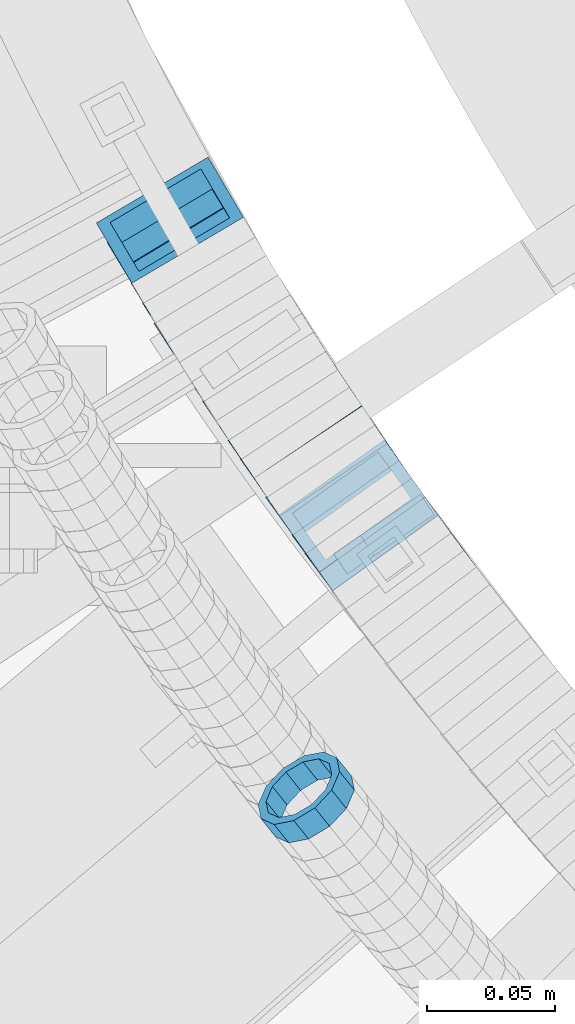
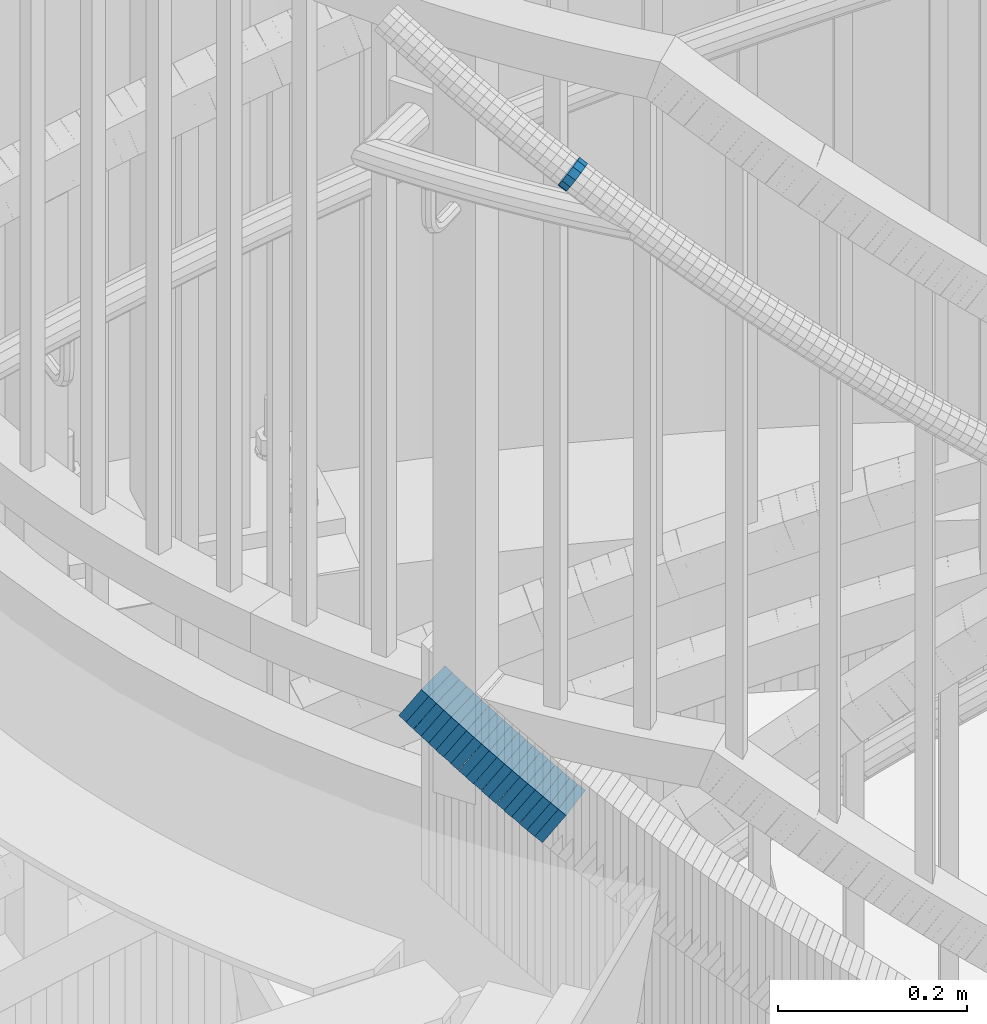
# One storey, part 725 of 975: 20 members.
"""IFC2X3 building model written with IfcOpenShell, lengths in millimetres."""

from ifc_helpers import new_model, si_unit, frame, origin_with_axes, place, context, subcontext, project, spatial, faceted_brep, material, type_object, element, save


model = new_model("IFC2X3")

# Units and contexts
model_context = context("Model", 3, precision=1e-05, world=origin_with_axes())
body_context = subcontext(model_context, "Body", "Model", "MODEL_VIEW")
ifc_project = project(units=[si_unit("LENGTHUNIT", "METRE", prefix="MILLI"), si_unit("AREAUNIT", "SQUARE_METRE"), si_unit("VOLUMEUNIT", "CUBIC_METRE"), si_unit("MASSUNIT", "GRAM", prefix="KILO"), si_unit("TIMEUNIT", "SECOND"), si_unit("PLANEANGLEUNIT", "RADIAN"), si_unit("SOLIDANGLEUNIT", "STERADIAN"), si_unit("THERMODYNAMICTEMPERATUREUNIT", "DEGREE_CELSIUS"), si_unit("LUMINOUSINTENSITYUNIT", "LUMEN")], contexts=[model_context])

# Site, building, storey
site_placement = place(None, origin_with_axes())
site = spatial("IfcSite", under=ifc_project, at=site_placement, CompositionType="ELEMENT")
building_placement = place(site_placement, origin_with_axes())
building = spatial("IfcBuilding", under=site, at=building_placement, Name="Undefined", CompositionType="ELEMENT")
storey_placement = place(building_placement, origin_with_axes())
storey = spatial("IfcBuildingStorey", under=building, at=storey_placement, Name="Undefined", CompositionType="ELEMENT", Elevation=0.0)

# Members
ifc_material = material()
member_type_1 = type_object("IfcMemberType", PredefinedType="NOTDEFINED")
member_1_placement = place(storey_placement, frame((33576.5249931983, 2482.7928515664, 5027.28408551308), z_axis=(-0.778753909161124, -0.627329537776014, 1.69853592524305e-10), x_axis=(-0.534001163916143, 0.662897996896017, 0.524794247917652)))
element("IfcMember", 1, at=member_1_placement, inside=storey, type_object=member_type_1, material=ifc_material, Name="WALL", context=body_context, shape_type="Brep", body=[
    faceted_brep([(-2.1246523829177e-07, -15.367000000002, 0.0), (-1.83998054126278e-07, -13.3082123799541, 7.68350000000009), (10.8613995415399, -13.3082123799322, 7.68349999999191), (10.8613995415435, -15.3669999999729, -8.18545231595635e-12), (-1.06232619145885e-07, -7.68349999999919, 13.3082123799559), (10.8613995415217, -7.683499999981, 13.3082123799504), (-3.63797880709171e-12, 3.63797880709171e-12, 15.3670000000002), (10.8613995415071, 3.63797880709171e-12, 15.3669999999984), (1.06225343188271e-07, 7.68350000000646, 13.3082123799559), (10.861399541478, 7.68349999998463, 13.3082123799586), (1.8399441614747e-07, 13.308212379965, 7.68350000000009), (10.8613995414671, 13.3082123799322, 7.68350000000555), (2.12461600312963e-07, 15.3670000000093, 0.0), (10.8613995414562, 15.3669999999693, 7.27595761418343e-12), (1.8399441614747e-07, 13.308212379965, -7.68350000000009), (10.8613995414671, 13.3082123799322, -7.68349999999191), (1.06225343188271e-07, 7.68350000000646, -13.3082123799559), (10.861399541478, 7.683499999981, -13.3082123799513), (-3.63797880709171e-12, 3.63797880709171e-12, -15.3670000000002), (10.8613995415035, -3.63797880709171e-12, -15.3670000000002), (-1.06232619145885e-07, -7.68349999999919, -13.3082123799559), (10.8613995415253, -7.68349999998827, -13.3082123799586), (-1.83998054126278e-07, -13.3082123799541, -7.68350000000009), (10.8613995415435, -13.3082123799286, -7.68350000000828), (-2.63386027654633e-07, -19.0500000000029, 0.0), (-2.28097633225843e-07, -16.4977839420972, -9.52499999999964), (10.8613995415471, -16.4977839420717, -9.52500000000782), (10.8613995415581, -19.0499999999629, -1.09139364212751e-11), (-1.31691194837913e-07, -9.52500000000146, -16.4977839420935), (10.861399541529, -9.5249999999869, -16.4977839420972), (-3.63797880709171e-12, 3.63797880709171e-12, -19.0500000000002), (10.8613995415035, -7.27595761418343e-12, -19.0499999999984), (1.31687556859106e-07, 9.52500000000509, -16.4977839420935), (10.861399541478, 9.52499999997963, -16.497783942089), (2.28097633225843e-07, 16.4977839421044, -9.52499999999964), (10.8613995414526, 16.4977839420644, -9.52499999999236), (2.63382389675826e-07, 19.0500000000138, 0.0), (10.8613995414489, 19.0499999999665, 8.18545231595635e-12), (2.28097633225843e-07, 16.4977839421044, 9.52499999999964), (10.8613995414598, 16.4977839420644, 9.52500000000691), (1.31687556859106e-07, 9.52500000000509, 16.4977839420935), (10.8613995414744, 9.5249999999869, 16.4977839420972), (-3.63797880709171e-12, 3.63797880709171e-12, 19.0500000000002), (10.8613995414998, 3.63797880709171e-12, 19.0499999999993), (-1.31691194837913e-07, -9.52500000000146, 16.4977839420935), (10.861399541529, -9.52499999997599, 16.4977839420862), (-2.28097633225843e-07, -16.4977839420972, 9.52499999999964), (10.8613995415508, -16.4977839420644, 9.52499999999145)], [[[0, 1, 2, 3]], [[1, 4, 5, 2]], [[4, 6, 7, 5]], [[6, 8, 9, 7]], [[8, 10, 11, 9]], [[10, 12, 13, 11]], [[12, 14, 15, 13]], [[14, 16, 17, 15]], [[16, 18, 19, 17]], [[18, 20, 21, 19]], [[20, 22, 23, 21]], [[22, 0, 3, 23]], [[24, 25, 26, 27]], [[25, 28, 29, 26]], [[28, 30, 31, 29]], [[30, 32, 33, 31]], [[32, 34, 35, 33]], [[34, 36, 37, 35]], [[36, 38, 39, 37]], [[38, 40, 41, 39]], [[40, 42, 43, 41]], [[42, 44, 45, 43]], [[44, 46, 47, 45]], [[46, 24, 27, 47]], [[29, 31, 33, 35, 37, 39, 41, 43, 45, 47, 27, 26], [5, 7, 9, 11, 13, 15, 17, 19, 21, 23, 3, 2]], [[46, 44, 42, 40, 38, 36, 34, 32, 30, 28, 25, 24], [22, 20, 18, 16, 14, 12, 10, 8, 6, 4, 1, 0]]]),
])
member_type_2 = type_object("IfcMemberType", Name="HSS2X2X.188_TUBES", PredefinedType="NOTDEFINED")
member_2_placement = place(storey_placement, frame((33524.7847360812, 2704.77711161195, 4240.01119105509), z_axis=(-0.861365903149515, -0.507985020341565, -1.39797521114815e-10), x_axis=(-0.427763564984691, 0.725338217974112, 0.539354059980759)))
element("IfcMember", 2, at=member_2_placement, inside=storey, type_object=member_type_2, material=ifc_material, Name="WALL", ObjectType="HSS2X2X.188_TUBES", context=body_context, shape_type="Brep", body=[
    faceted_brep([(0.0, 20.6374999999753, -20.6375000000298), (0.0, -20.6375000000153, -20.6375000000153), (10.7466273779264, -20.6375000000044, -20.6374999999753), (10.746627377941, 20.6375000000298, -20.6374999999352), (0.0, -20.6374999999825, 20.6375000000335), (10.7466273778828, -20.6375000000189, 20.6374999999425), (0.0, 20.6375000000116, 20.6375000000189), (10.7466273778973, 20.6375000000153, 20.6374999999825), (0.0, 25.3999999999724, -25.4000000000342), (0.0, 25.400000000016, 25.4000000000196), (10.7466273778919, 25.4000000000142, 25.3999999999724), (10.7466273779501, 25.4000000000342, -25.3999999999178), (0.0, -25.399999999976, 25.4000000000378), (10.7466273778737, -25.4000000000233, 25.3999999999251), (0.0, -25.400000000016, -25.4000000000196), (10.7466273779319, -25.4000000000033, -25.3999999999651)], [[[0, 1, 2, 3]], [[1, 4, 5, 2]], [[4, 6, 7, 5]], [[6, 0, 3, 7]], [[8, 9, 10, 11]], [[9, 12, 13, 10]], [[12, 14, 15, 13]], [[14, 8, 11, 15]], [[13, 15, 11, 10], [5, 7, 3, 2]], [[14, 12, 9, 8], [6, 4, 1, 0]]]),
])
member_3_placement = place(storey_placement, frame((33529.1929334797, 2697.21250980191, 4234.18292891483), z_axis=(-0.856522488393593, -0.516109704303308, -3.67035681847483e-11), x_axis=(-0.433147529838168, 0.71884058173132, 0.543738388796737)))
element("IfcMember", 3, at=member_3_placement, inside=storey, type_object=member_type_2, material=ifc_material, Name="WALL", ObjectType="HSS2X2X.188_TUBES", context=body_context, shape_type="Brep", body=[
    faceted_brep([(0.0, 20.6374999999753, -20.6375000000298), (0.0, -20.6375000000153, -20.6375000000153), (10.8508064216348, -20.6375000000044, -20.6375000000116), (10.8508064216512, 20.6375000000189, -20.6374999999862), (0.0, -20.6374999999825, 20.6375000000335), (10.850806421633, -20.6375000000189, 20.6374999999716), (0.0, 20.6375000000116, 20.6375000000189), (10.850806421653, 20.6375000000044, 20.6375000000007), (0.0, 25.3999999999724, -25.4000000000342), (0.0, 25.400000000016, 25.4000000000196), (10.850806421653, 25.4000000000051, 25.4000000000015), (10.8508064216512, 25.4000000000215, -25.3999999999796), (0.0, -25.399999999976, 25.4000000000378), (10.850806421633, -25.4000000000215, 25.3999999999687), (0.0, -25.400000000016, -25.4000000000196), (10.8508064216312, -25.4000000000051, -25.400000000016)], [[[0, 1, 2, 3]], [[1, 4, 5, 2]], [[4, 6, 7, 5]], [[6, 0, 3, 7]], [[8, 9, 10, 11]], [[9, 12, 13, 10]], [[12, 14, 15, 13]], [[14, 8, 11, 15]], [[13, 15, 11, 10], [5, 7, 3, 2]], [[14, 12, 9, 8], [6, 4, 1, 0]]]),
])
member_4_placement = place(storey_placement, frame((33533.9786692788, 2689.27022485862, 4228.27621748456), z_axis=(-0.856522488393593, -0.516109704303308, -3.67035681847483e-11), x_axis=(-0.435315828975542, 0.722439035959217, 0.537198257969676)))
element("IfcMember", 4, at=member_4_placement, inside=storey, type_object=member_type_2, material=ifc_material, Name="WALL", ObjectType="HSS2X2X.188_TUBES", context=body_context, shape_type="Brep", body=[
    faceted_brep([(0.0, 20.6374999999753, -20.6375000000298), (0.0, -20.6375000000153, -20.6375000000153), (10.7967587729272, -20.6374999999844, -20.6374999999425), (10.7967587729127, 20.6375000000007, -20.6374999999753), (0.0, -20.6374999999825, 20.6375000000335), (10.7967587728654, -20.6375000000135, 20.6374999999352), (0.0, 20.6375000000116, 20.6375000000189), (10.7967587728508, 20.6374999999716, 20.6374999999025), (0.0, 25.3999999999724, -25.4000000000342), (0.0, 25.400000000016, 25.4000000000196), (10.7967587728399, 25.3999999999651, 25.399999999885), (10.7967587729163, 25.4000000000015, -25.3999999999614), (0.0, -25.399999999976, 25.4000000000378), (10.7967587728617, -25.400000000016, 25.3999999999287), (0.0, -25.400000000016, -25.4000000000196), (10.7967587729381, -25.3999999999778, -25.3999999999214)], [[[0, 1, 2, 3]], [[1, 4, 5, 2]], [[4, 6, 7, 5]], [[6, 0, 3, 7]], [[8, 9, 10, 11]], [[9, 12, 13, 10]], [[12, 14, 15, 13]], [[14, 8, 11, 15]], [[13, 15, 11, 10], [5, 7, 3, 2]], [[14, 12, 9, 8], [6, 4, 1, 0]]]),
])
member_5_placement = place(storey_placement, frame((33538.4888254848, 2681.73220869061, 4222.5348533772), z_axis=(-0.853555730562404, -0.521001549732897, 0.0), x_axis=(-0.438239154078857, 0.717966273129345, 0.540805764097431)))
element("IfcMember", 5, at=member_5_placement, inside=storey, type_object=member_type_2, material=ifc_material, Name="WALL", ObjectType="HSS2X2X.188_TUBES", context=body_context, shape_type="Brep", body=[
    faceted_brep([(0.0, 20.6374999999753, -20.6375000000298), (0.0, -20.6375000000153, -20.6375000000153), (10.7247377590011, -20.6375000000189, -20.6375000000589), (10.7247377589938, 20.6374999999844, -20.6375000000698), (0.0, -20.6374999999825, 20.6375000000335), (10.7247377590484, -20.6374999999771, 20.6375000000517), (0.0, 20.6375000000116, 20.6375000000189), (10.7247377590447, 20.6375000000262, 20.6375000000407), (0.0, 25.3999999999724, -25.4000000000342), (0.0, 25.400000000016, 25.4000000000196), (10.7247377590484, 25.4000000000342, 25.400000000056), (10.7247377589902, 25.3999999999778, -25.4000000000851), (0.0, -25.399999999976, 25.4000000000378), (10.7247377590556, -25.3999999999724, 25.4000000000633), (0.0, -25.400000000016, -25.4000000000196), (10.7247377589938, -25.4000000000251, -25.4000000000742)], [[[0, 1, 2, 3]], [[1, 4, 5, 2]], [[4, 6, 7, 5]], [[6, 0, 3, 7]], [[8, 9, 10, 11]], [[9, 12, 13, 10]], [[12, 14, 15, 13]], [[14, 8, 11, 15]], [[13, 15, 11, 10], [5, 7, 3, 2]], [[14, 12, 9, 8], [6, 4, 1, 0]]]),
])
member_6_placement = place(storey_placement, frame((33543.0832242027, 2674.11988442208, 4216.6987103152), z_axis=(-0.848616882638762, -0.529007926689638, 4.62032403447665e-11), x_axis=(-0.445726452193525, 0.715019517310377, 0.53858613023379)))
element("IfcMember", 6, at=member_6_placement, inside=storey, type_object=member_type_2, material=ifc_material, Name="WALL", ObjectType="HSS2X2X.188_TUBES", context=body_context, shape_type="Brep", body=[
    faceted_brep([(0.0, 20.6374999999753, -20.6375000000298), (0.0, -20.6375000000153, -20.6375000000153), (10.7745069492303, -20.6375000000116, -20.637500000048), (10.7745069491903, 20.6374999999607, -20.6375000001135), (0.0, -20.6374999999825, 20.6375000000335), (10.7745069492958, -20.6374999999771, 20.6375000000698), (0.0, 20.6375000000116, 20.6375000000189), (10.7745069492557, 20.6374999999916, 20.6375000000044), (0.0, 25.3999999999724, -25.4000000000342), (0.0, 25.400000000016, 25.4000000000196), (10.7745069492557, 25.3999999999905, 25.4000000000124), (10.7745069491793, 25.3999999999542, -25.4000000001324), (0.0, -25.399999999976, 25.4000000000378), (10.7745069493085, -25.3999999999724, 25.4000000000924), (0.0, -25.400000000016, -25.4000000000196), (10.7745069492321, -25.4000000000087, -25.4000000000524)], [[[0, 1, 2, 3]], [[1, 4, 5, 2]], [[4, 6, 7, 5]], [[6, 0, 3, 7]], [[8, 9, 10, 11]], [[9, 12, 13, 10]], [[12, 14, 15, 13]], [[14, 8, 11, 15]], [[13, 15, 11, 10], [5, 7, 3, 2]], [[14, 12, 9, 8], [6, 4, 1, 0]]]),
])
member_7_placement = place(storey_placement, frame((33547.5820319711, 2666.7629689259, 4210.91993629906), z_axis=(-0.840459118503239, -0.541874958015923, -1.81238647201098e-10), x_axis=(-0.45611500504468, 0.707443681069383, 0.539891230052955)))
element("IfcMember", 7, at=member_7_placement, inside=storey, type_object=member_type_2, material=ifc_material, Name="WALL", ObjectType="HSS2X2X.188_TUBES", context=body_context, shape_type="Brep", body=[
    faceted_brep([(0.0, 20.6374999999753, -20.6375000000298), (0.0, -20.6375000000153, -20.6375000000153), (10.7387150069171, -20.6374999999953, -20.6374999999789), (10.7387150068989, 20.6374999999898, -20.6375000000189), (0.0, -20.6374999999825, 20.6375000000335), (10.7387150069117, -20.6375000000098, 20.6374999999935), (0.0, 20.6375000000116, 20.6375000000189), (10.7387150068935, 20.6374999999771, 20.6374999999571), (0.0, 25.3999999999724, -25.4000000000342), (0.0, 25.400000000016, 25.4000000000196), (10.7387150068953, 25.3999999999705, 25.3999999999505), (10.7387150068953, 25.3999999999887, -25.4000000000233), (0.0, -25.399999999976, 25.4000000000378), (10.7387150069153, -25.4000000000087, 25.3999999999942), (0.0, -25.400000000016, -25.4000000000196), (10.7387150069171, -25.3999999999924, -25.3999999999724)], [[[0, 1, 2, 3]], [[1, 4, 5, 2]], [[4, 6, 7, 5]], [[6, 0, 3, 7]], [[8, 9, 10, 11]], [[9, 12, 13, 10]], [[12, 14, 15, 13]], [[14, 8, 11, 15]], [[13, 15, 11, 10], [5, 7, 3, 2]], [[14, 12, 9, 8], [6, 4, 1, 0]]]),
])
member_8_placement = place(storey_placement, frame((33552.5869071402, 2659.08077527545, 4205.15724533005), z_axis=(-0.845488903197307, -0.533992991124617, 0.0), x_axis=(-0.448696118951929, 0.710435520923802, 0.542174476941881)))
element("IfcMember", 8, at=member_8_placement, inside=storey, type_object=member_type_2, material=ifc_material, Name="WALL", ObjectType="HSS2X2X.188_TUBES", context=body_context, shape_type="Brep", body=[
    faceted_brep([(0.0, 20.6374999999753, -20.6375000000298), (0.0, -20.6375000000153, -20.6375000000153), (10.6985980389491, -20.6375000000317, -20.6375000000698), (10.6985980389982, 20.6375000000116, -20.6374999999643), (0.0, -20.6374999999825, 20.6375000000335), (10.6985980389818, -20.6374999999989, 20.6374999999789), (0.0, 20.6375000000116, 20.6375000000189), (10.6985980390309, 20.6375000000407, 20.6375000000808), (0.0, 25.3999999999724, -25.4000000000342), (0.0, 25.400000000016, 25.4000000000196), (10.6985980390382, 25.4000000000487, 25.4000000000997), (10.6985980390036, 25.4000000000142, -25.3999999999542), (0.0, -25.399999999976, 25.4000000000378), (10.6985980389763, -25.4000000000033, 25.3999999999724), (0.0, -25.400000000016, -25.4000000000196), (10.6985980389418, -25.400000000036, -25.4000000000851)], [[[0, 1, 2, 3]], [[1, 4, 5, 2]], [[4, 6, 7, 5]], [[6, 0, 3, 7]], [[8, 9, 10, 11]], [[9, 12, 13, 10]], [[12, 14, 15, 13]], [[14, 8, 11, 15]], [[13, 15, 11, 10], [5, 7, 3, 2]], [[14, 12, 9, 8], [6, 4, 1, 0]]]),
])
member_9_placement = place(storey_placement, frame((33557.0792621499, 2651.8225301897, 4199.37831945769), z_axis=(-0.837166200021067, -0.546948584002452, 6.13090378465131e-12), x_axis=(-0.459128463951037, 0.702747648925274, 0.543458181942236)))
element("IfcMember", 9, at=member_9_placement, inside=storey, type_object=member_type_2, material=ifc_material, Name="WALL", ObjectType="HSS2X2X.188_TUBES", context=body_context, shape_type="Brep", body=[
    faceted_brep([(0.0, 20.6374999999753, -20.6375000000298), (0.0, -20.6375000000153, -20.6375000000153), (10.6709887076922, -20.6374999999844, -20.6374999999825), (10.6709887076995, 20.6375000000171, -20.6374999999753), (0.0, -20.6374999999825, 20.6375000000335), (10.6709887076922, -20.6374999999971, 20.6375000000153), (0.0, 20.6375000000116, 20.6375000000189), (10.6709887076941, 20.6375000000025, 20.6375000000189), (0.0, 25.3999999999724, -25.4000000000342), (0.0, 25.400000000016, 25.4000000000196), (10.6709887076959, 25.3999999999996, 25.4000000000233), (10.6709887077013, 25.4000000000178, -25.3999999999724), (0.0, -25.399999999976, 25.4000000000378), (10.6709887076904, -25.3999999999978, 25.400000000016), (0.0, -25.400000000016, -25.4000000000196), (10.6709887076959, -25.3999999999796, -25.3999999999796)], [[[0, 1, 2, 3]], [[1, 4, 5, 2]], [[4, 6, 7, 5]], [[6, 0, 3, 7]], [[8, 9, 10, 11]], [[9, 12, 13, 10]], [[12, 14, 15, 13]], [[14, 8, 11, 15]], [[13, 15, 11, 10], [5, 7, 3, 2]], [[14, 12, 9, 8], [6, 4, 1, 0]]]),
])
member_10_placement = place(storey_placement, frame((33562.1726114878, 2644.00075202283, 4193.4759748694), z_axis=(-0.835417082243856, -0.549616501476404, -1.6539343050681e-10), x_axis=(-0.465746433038707, 0.707934578058823, 0.530950933044097)))
element("IfcMember", 10, at=member_10_placement, inside=storey, type_object=member_type_2, material=ifc_material, Name="WALL", ObjectType="HSS2X2X.188_TUBES", context=body_context, shape_type="Brep", body=[
    faceted_brep([(0.0, 20.6374999999753, -20.6375000000298), (0.0, -20.6375000000153, -20.6375000000153), (10.7387150069171, -20.6374999999953, -20.6374999999789), (10.7387150068989, 20.6374999999898, -20.6375000000189), (0.0, -20.6374999999825, 20.6375000000335), (10.7387150069117, -20.6375000000098, 20.6374999999935), (0.0, 20.6375000000116, 20.6375000000189), (10.7387150068935, 20.6374999999771, 20.6374999999571), (0.0, 25.3999999999724, -25.4000000000342), (0.0, 25.400000000016, 25.4000000000196), (10.7387150068953, 25.3999999999705, 25.3999999999505), (10.7387150068953, 25.3999999999887, -25.4000000000233), (0.0, -25.399999999976, 25.4000000000378), (10.7387150069153, -25.4000000000087, 25.3999999999942), (0.0, -25.400000000016, -25.4000000000196), (10.7387150069171, -25.3999999999924, -25.3999999999724)], [[[0, 1, 2, 3]], [[1, 4, 5, 2]], [[4, 6, 7, 5]], [[6, 0, 3, 7]], [[8, 9, 10, 11]], [[9, 12, 13, 10]], [[12, 14, 15, 13]], [[14, 8, 11, 15]], [[13, 15, 11, 10], [5, 7, 3, 2]], [[14, 12, 9, 8], [6, 4, 1, 0]]]),
])
member_11_placement = place(storey_placement, frame((33566.6661904193, 2637.05720336357, 4187.89803033736), z_axis=(-0.828588968917096, -0.559857410943987, 0.0), x_axis=(-0.469530142078345, 0.694904609116148, 0.54465496409105)))
element("IfcMember", 11, at=member_11_placement, inside=storey, type_object=member_type_2, material=ifc_material, Name="WALL", ObjectType="HSS2X2X.188_TUBES", context=body_context, shape_type="Brep", body=[
    faceted_brep([(0.0, 20.6374999999753, -20.6375000000298), (0.0, -20.6375000000153, -20.6375000000153), (10.648004507897, -20.6374999999862, -20.637499999968), (10.6480045078188, 20.6374999999771, -20.6375000000808), (0.0, -20.6374999999825, 20.6375000000335), (10.6480045079406, -20.6374999999698, 20.6375000001062), (0.0, 20.6375000000116, 20.6375000000189), (10.6480045078679, 20.6374999999935, 20.6375000000007), (0.0, 25.3999999999724, -25.4000000000342), (0.0, 25.400000000016, 25.4000000000196), (10.6480045078661, 25.3999999999905, 25.4000000000015), (10.648004507806, 25.3999999999705, -25.4000000000997), (0.0, -25.399999999976, 25.4000000000378), (10.6480045079552, -25.3999999999633, 25.4000000001288), (0.0, -25.400000000016, -25.4000000000196), (10.6480045078988, -25.3999999999814, -25.3999999999651)], [[[0, 1, 2, 3]], [[1, 4, 5, 2]], [[4, 6, 7, 5]], [[6, 0, 3, 7]], [[8, 9, 10, 11]], [[9, 12, 13, 10]], [[12, 14, 15, 13]], [[14, 8, 11, 15]], [[13, 15, 11, 10], [5, 7, 3, 2]], [[14, 12, 9, 8], [6, 4, 1, 0]]]),
])
member_12_placement = place(storey_placement, frame((33571.8753774342, 2629.39921007816, 4182.03985056992), z_axis=(-0.832050294337844, -0.554700196225228, 0.0), x_axis=(-0.466475554081945, 0.699713332123061, 0.541111643095199)))
element("IfcMember", 12, at=member_12_placement, inside=storey, type_object=member_type_2, material=ifc_material, Name="WALL", ObjectType="HSS2X2X.188_TUBES", context=body_context, shape_type="Brep", body=[
    faceted_brep([(0.0, 20.6374999999753, -20.6375000000298), (0.0, -20.6375000000153, -20.6375000000153), (10.7247377590011, -20.6375000000189, -20.6375000000589), (10.7247377589938, 20.6374999999844, -20.6375000000698), (0.0, -20.6374999999825, 20.6375000000335), (10.7247377590484, -20.6374999999771, 20.6375000000517), (0.0, 20.6375000000116, 20.6375000000189), (10.7247377590447, 20.6375000000262, 20.6375000000407), (0.0, 25.3999999999724, -25.4000000000342), (0.0, 25.400000000016, 25.4000000000196), (10.7247377590484, 25.4000000000342, 25.400000000056), (10.7247377589902, 25.3999999999778, -25.4000000000851), (0.0, -25.399999999976, 25.4000000000378), (10.7247377590556, -25.3999999999724, 25.4000000000633), (0.0, -25.400000000016, -25.4000000000196), (10.7247377589938, -25.4000000000251, -25.4000000000742)], [[[0, 1, 2, 3]], [[1, 4, 5, 2]], [[4, 6, 7, 5]], [[6, 0, 3, 7]], [[8, 9, 10, 11]], [[9, 12, 13, 10]], [[12, 14, 15, 13]], [[14, 8, 11, 15]], [[13, 15, 11, 10], [5, 7, 3, 2]], [[14, 12, 9, 8], [6, 4, 1, 0]]]),
])
member_13_placement = place(storey_placement, frame((33576.6594219896, 2622.08926198097, 4176.25033670451), z_axis=(-0.823392066704671, -0.567472910796463, 0.0), x_axis=(-0.479216648185213, 0.69533396026852, 0.535595078206873)))
element("IfcMember", 13, at=member_13_placement, inside=storey, type_object=member_type_2, material=ifc_material, Name="WALL", ObjectType="HSS2X2X.188_TUBES", context=body_context, shape_type="Brep", body=[
    faceted_brep([(0.0, 20.6374999999753, -20.6375000000298), (0.0, -20.6375000000153, -20.6375000000153), (10.6395488625676, -20.6374999999771, -20.6374999999716), (10.6395488625531, 20.6374999999916, -20.6375000000189), (0.0, -20.6374999999825, 20.6375000000335), (10.6395488625731, -20.6374999999844, 20.6375000000153), (0.0, 20.6375000000116, 20.6375000000189), (10.6395488625585, 20.6374999999825, 20.637499999968), (0.0, 25.3999999999724, -25.4000000000342), (0.0, 25.400000000016, 25.4000000000196), (10.6395488625567, 25.3999999999778, 25.3999999999614), (10.6395488625494, 25.3999999999887, -25.4000000000233), (0.0, -25.399999999976, 25.4000000000378), (10.6395488625749, -25.3999999999851, 25.400000000016), (0.0, -25.400000000016, -25.4000000000196), (10.6395488625658, -25.399999999976, -25.3999999999687)], [[[0, 1, 2, 3]], [[1, 4, 5, 2]], [[4, 6, 7, 5]], [[6, 0, 3, 7]], [[8, 9, 10, 11]], [[9, 12, 13, 10]], [[12, 14, 15, 13]], [[14, 8, 11, 15]], [[13, 15, 11, 10], [5, 7, 3, 2]], [[14, 12, 9, 8], [6, 4, 1, 0]]]),
])
member_14_placement = place(storey_placement, frame((33581.4480099697, 2615.08453721768, 4170.61633481282), z_axis=(-0.819759137821163, -0.572708438875056, 0.0), x_axis=(-0.479895065914507, 0.68690862287762, 0.545763015902765)))
element("IfcMember", 14, at=member_14_placement, inside=storey, type_object=member_type_2, material=ifc_material, Name="WALL", ObjectType="HSS2X2X.188_TUBES", context=body_context, shape_type="Brep", body=[
    faceted_brep([(0.0, 20.6374999999753, -20.6375000000298), (0.0, -20.6375000000153, -20.6375000000153), (10.6348483769107, -20.637499999988, -20.6374999999825), (10.6348483768415, 20.6374999999734, -20.6375000001026), (0.0, -20.6374999999825, 20.6375000000335), (10.6348483769852, -20.6374999999589, 20.6375000001462), (0.0, 20.6375000000116, 20.6375000000189), (10.6348483769161, 20.6375000000044, 20.6375000000226), (0.0, 25.3999999999724, -25.4000000000342), (0.0, 25.400000000016, 25.4000000000196), (10.6348483769179, 25.4000000000015, 25.4000000000233), (10.6348483768288, 25.3999999999669, -25.4000000001324), (0.0, -25.399999999976, 25.4000000000378), (10.6348483769998, -25.3999999999505, 25.4000000001688), (0.0, -25.400000000016, -25.4000000000196), (10.6348483769107, -25.3999999999887, -25.3999999999833)], [[[0, 1, 2, 3]], [[1, 4, 5, 2]], [[4, 6, 7, 5]], [[6, 0, 3, 7]], [[8, 9, 10, 11]], [[9, 12, 13, 10]], [[12, 14, 15, 13]], [[14, 8, 11, 15]], [[13, 15, 11, 10], [5, 7, 3, 2]], [[14, 12, 9, 8], [6, 4, 1, 0]]]),
])
member_15_placement = place(storey_placement, frame((33586.8594219896, 2607.38926198097, 4164.75033670451), z_axis=(-0.823392066704671, -0.567472910796463, 0.0), x_axis=(-0.479216648185213, 0.69533396026852, 0.535595078206873)))
element("IfcMember", 15, at=member_15_placement, inside=storey, type_object=member_type_2, material=ifc_material, Name="WALL", ObjectType="HSS2X2X.188_TUBES", context=body_context, shape_type="Brep", body=[
    faceted_brep([(0.0, 20.6374999999753, -20.6375000000298), (0.0, -20.6375000000153, -20.6375000000153), (10.6395488625676, -20.6374999999771, -20.6374999999716), (10.6395488625531, 20.6374999999916, -20.6375000000189), (0.0, -20.6374999999825, 20.6375000000335), (10.6395488625731, -20.6374999999844, 20.6375000000153), (0.0, 20.6375000000116, 20.6375000000189), (10.6395488625585, 20.6374999999825, 20.637499999968), (0.0, 25.3999999999724, -25.4000000000342), (0.0, 25.400000000016, 25.4000000000196), (10.6395488625567, 25.3999999999778, 25.3999999999614), (10.6395488625494, 25.3999999999887, -25.4000000000233), (0.0, -25.399999999976, 25.4000000000378), (10.6395488625749, -25.3999999999851, 25.400000000016), (0.0, -25.400000000016, -25.4000000000196), (10.6395488625658, -25.399999999976, -25.3999999999687)], [[[0, 1, 2, 3]], [[1, 4, 5, 2]], [[4, 6, 7, 5]], [[6, 0, 3, 7]], [[8, 9, 10, 11]], [[9, 12, 13, 10]], [[12, 14, 15, 13]], [[14, 8, 11, 15]], [[13, 15, 11, 10], [5, 7, 3, 2]], [[14, 12, 9, 8], [6, 4, 1, 0]]]),
])
member_16_placement = place(storey_placement, frame((33591.4241006038, 2600.56714948544, 4159.12367431757), z_axis=(-0.810679228188928, -0.585490554136447, 0.0), x_axis=(-0.492741605110257, 0.682257607152466, 0.540120605120707)))
element("IfcMember", 16, at=member_16_placement, inside=storey, type_object=member_type_2, material=ifc_material, Name="WALL", ObjectType="HSS2X2X.188_TUBES", context=body_context, shape_type="Brep", body=[
    faceted_brep([(0.0, 20.6374999999753, -20.6375000000298), (0.0, -20.6375000000153, -20.6375000000153), (10.5531985672587, -20.6374999999916, -20.6375000000007), (10.5531985672878, 20.6375000000062, -20.6374999999789), (0.0, -20.6374999999825, 20.6375000000335), (10.5531985672114, -20.6375000000353, 20.6374999999171), (0.0, 20.6375000000116, 20.6375000000189), (10.5531985672333, 20.6374999999607, 20.6374999999316), (0.0, 25.3999999999724, -25.4000000000342), (0.0, 25.400000000016, 25.4000000000196), (10.5531985672314, 25.399999999956, 25.3999999999251), (10.5531985672933, 25.4000000000106, -25.3999999999724), (0.0, -25.399999999976, 25.4000000000378), (10.5531985672023, -25.4000000000397, 25.3999999999069), (0.0, -25.400000000016, -25.4000000000196), (10.5531985672642, -25.3999999999851, -25.3999999999869)], [[[0, 1, 2, 3]], [[1, 4, 5, 2]], [[4, 6, 7, 5]], [[6, 0, 3, 7]], [[8, 9, 10, 11]], [[9, 12, 13, 10]], [[12, 14, 15, 13]], [[14, 8, 11, 15]], [[13, 15, 11, 10], [5, 7, 3, 2]], [[14, 12, 9, 8], [6, 4, 1, 0]]]),
])
member_17_placement = place(storey_placement, frame((33596.7469091849, 2593.25014814315, 4153.37557518153), z_axis=(-0.814486661754882, -0.580182279825392, 0.0), x_axis=(-0.487088716912269, 0.683797621876688, 0.543291260902055)))
element("IfcMember", 17, at=member_17_placement, inside=storey, type_object=member_type_2, material=ifc_material, Name="WALL", ObjectType="HSS2X2X.188_TUBES", context=body_context, shape_type="Brep", body=[
    faceted_brep([(0.0, 20.6374999999753, -20.6375000000298), (0.0, -20.6375000000153, -20.6375000000153), (10.6831643251735, -20.6375000000498, -20.6375000000953), (10.6831643252044, 20.637499999988, -20.6375000000226), (0.0, -20.6374999999825, 20.6375000000335), (10.6831643251935, -20.6375000000135, 20.637499999968), (0.0, 20.6375000000116, 20.6375000000189), (10.6831643252244, 20.6375000000226, 20.6375000000407), (0.0, 25.3999999999724, -25.4000000000342), (0.0, 25.400000000016, 25.4000000000196), (10.6831643252317, 25.4000000000306, 25.4000000000597), (10.6831643252044, 25.3999999999905, -25.4000000000196), (0.0, -25.399999999976, 25.4000000000378), (10.6831643251917, -25.400000000016, 25.3999999999614), (0.0, -25.400000000016, -25.4000000000196), (10.6831643251644, -25.400000000056, -25.4000000001179)], [[[0, 1, 2, 3]], [[1, 4, 5, 2]], [[4, 6, 7, 5]], [[6, 0, 3, 7]], [[8, 9, 10, 11]], [[9, 12, 13, 10]], [[12, 14, 15, 13]], [[14, 8, 11, 15]], [[13, 15, 11, 10], [5, 7, 3, 2]], [[14, 12, 9, 8], [6, 4, 1, 0]]]),
])
member_18_placement = place(storey_placement, frame((33601.7259568387, 2586.12824288726, 4147.58259582463), z_axis=(-0.805336884132331, -0.592817428097411, 0.0), x_axis=(-0.49986655384694, 0.679063997791918, 0.537592331835232)))
element("IfcMember", 18, at=member_18_placement, inside=storey, type_object=member_type_2, material=ifc_material, Name="WALL", ObjectType="HSS2X2X.188_TUBES", context=body_context, shape_type="Brep", body=[
    faceted_brep([(0.0, 20.6374999999753, -20.6375000000298), (0.0, -20.6375000000153, -20.6375000000153), (10.6004716875832, -20.6375000000153, -20.6375000000553), (10.6004716875814, 20.6374999999898, -20.6375000000444), (0.0, -20.6374999999825, 20.6375000000335), (10.6004716876068, -20.6375000000044, 20.6374999999862), (0.0, 20.6375000000116, 20.6375000000189), (10.6004716876032, 20.6374999999989, 20.6374999999971), (0.0, 25.3999999999724, -25.4000000000342), (0.0, 25.400000000016, 25.4000000000196), (10.600471687605, 25.4000000000015, 25.4000000000051), (10.6004716875814, 25.3999999999869, -25.4000000000487), (0.0, -25.399999999976, 25.4000000000378), (10.6004716876068, -25.4000000000015, 25.3999999999905), (0.0, -25.400000000016, -25.4000000000196), (10.6004716875814, -25.4000000000178, -25.4000000000669)], [[[0, 1, 2, 3]], [[1, 4, 5, 2]], [[4, 6, 7, 5]], [[6, 0, 3, 7]], [[8, 9, 10, 11]], [[9, 12, 13, 10]], [[12, 14, 15, 13]], [[14, 8, 11, 15]], [[13, 15, 11, 10], [5, 7, 3, 2]], [[14, 12, 9, 8], [6, 4, 1, 0]]]),
])
member_19_placement = place(storey_placement, frame((33606.7989012124, 2579.18062957241, 4141.93875214641), z_axis=(-0.801352360250056, -0.598192606709298, 2.46101080847438e-10), x_axis=(-0.503076399222755, 0.673932535298482, 0.541044429239622)))
element("IfcMember", 19, at=member_19_placement, inside=storey, type_object=member_type_2, material=ifc_material, Name="WALL", ObjectType="HSS2X2X.188_TUBES", context=body_context, shape_type="Brep", body=[
    faceted_brep([(0.0, 20.6374999999753, -20.6375000000298), (0.0, -20.6375000000153, -20.6375000000153), (10.5422957651572, -20.6374999999771, -20.6374999999534), (10.5422957651481, 20.6375000000153, -20.6374999999789), (0.0, -20.6374999999825, 20.6375000000335), (10.5422957651535, -20.6374999999971, 20.6375000000298), (0.0, 20.6375000000116, 20.6375000000189), (10.5422957651444, 20.6374999999971, 20.6375000000044), (0.0, 25.3999999999724, -25.4000000000342), (0.0, 25.400000000016, 25.4000000000196), (10.5422957651426, 25.3999999999924, 25.3999999999905), (10.5422957651463, 25.4000000000178, -25.3999999999833), (0.0, -25.399999999976, 25.4000000000378), (10.5422957651499, -25.3999999999996, 25.4000000000269), (0.0, -25.400000000016, -25.4000000000196), (10.5422957651554, -25.3999999999742, -25.3999999999469)], [[[0, 1, 2, 3]], [[1, 4, 5, 2]], [[4, 6, 7, 5]], [[6, 0, 3, 7]], [[8, 9, 10, 11]], [[9, 12, 13, 10]], [[12, 14, 15, 13]], [[14, 8, 11, 15]], [[13, 15, 11, 10], [5, 7, 3, 2]], [[14, 12, 9, 8], [6, 4, 1, 0]]]),
])
member_20_placement = place(storey_placement, frame((33612.3259568387, 2571.82824288726, 4136.18259582463), z_axis=(-0.805336884132331, -0.592817428097411, 0.0), x_axis=(-0.49986655384694, 0.679063997791918, 0.537592331835232)))
element("IfcMember", 20, at=member_20_placement, inside=storey, type_object=member_type_2, material=ifc_material, Name="WALL", ObjectType="HSS2X2X.188_TUBES", context=body_context, shape_type="Brep", body=[
    faceted_brep([(0.0, 20.6374999999753, -20.6375000000298), (0.0, -20.6375000000153, -20.6375000000153), (10.6004716875832, -20.6375000000153, -20.6375000000553), (10.6004716875814, 20.6374999999898, -20.6375000000444), (0.0, -20.6374999999825, 20.6375000000335), (10.6004716876068, -20.6375000000044, 20.6374999999862), (0.0, 20.6375000000116, 20.6375000000189), (10.6004716876032, 20.6374999999989, 20.6374999999971), (0.0, 25.3999999999724, -25.4000000000342), (0.0, 25.400000000016, 25.4000000000196), (10.600471687605, 25.4000000000015, 25.4000000000051), (10.6004716875814, 25.3999999999869, -25.4000000000487), (0.0, -25.399999999976, 25.4000000000378), (10.6004716876068, -25.4000000000015, 25.3999999999905), (0.0, -25.400000000016, -25.4000000000196), (10.6004716875814, -25.4000000000178, -25.4000000000669)], [[[0, 1, 2, 3]], [[1, 4, 5, 2]], [[4, 6, 7, 5]], [[6, 0, 3, 7]], [[8, 9, 10, 11]], [[9, 12, 13, 10]], [[12, 14, 15, 13]], [[14, 8, 11, 15]], [[13, 15, 11, 10], [5, 7, 3, 2]], [[14, 12, 9, 8], [6, 4, 1, 0]]]),
])

save(model, "model.ifc")
